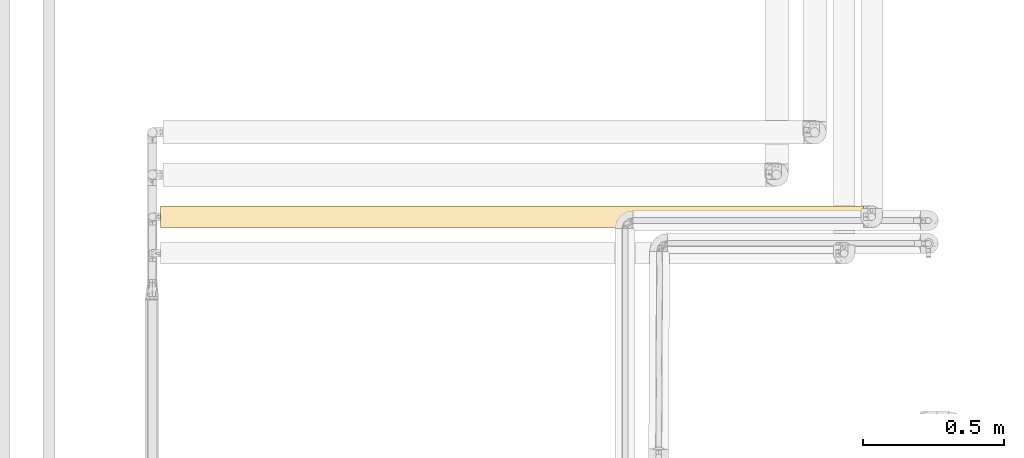
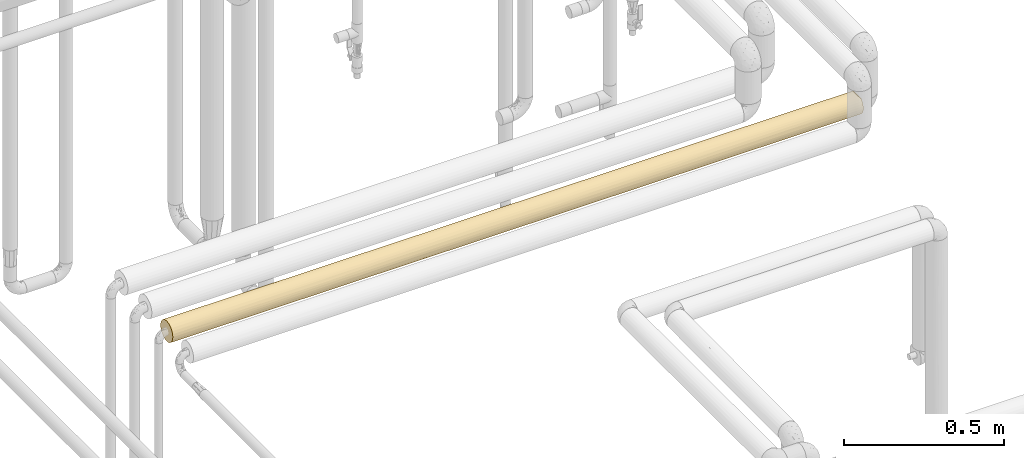
# One storey, part 31 of 827: 1 covering.
"""IFC2X3 building model written with IfcOpenShell, lengths in millimetres."""

from ifc_helpers import new_model, entity, si_unit, converted_unit, derived_unit, direction, frame, origin, place, context, subcontext, project, spatial, faceted_brep, element, save


model = new_model("IFC2X3")

# Units and contexts
model_context = context("Model", 3, precision=0.01, world=origin(), true_north=direction((6.12303176911189e-17, 1.0)))
body_context = subcontext(model_context, "Body", "Model", "MODEL_VIEW")
ifc_project = project(units=[si_unit("LENGTHUNIT", "METRE", prefix="MILLI"), si_unit("AREAUNIT", "SQUARE_METRE"), si_unit("VOLUMEUNIT", "CUBIC_METRE"), converted_unit("PLANEANGLEUNIT", "DEGREE", entity("IfcRatioMeasure", 0.0174532925199433), si_unit("PLANEANGLEUNIT", "RADIAN"), dimensions=[0, 0, 0, 0, 0, 0, 0]), si_unit("MASSUNIT", "GRAM", prefix="KILO"), derived_unit("MASSDENSITYUNIT", [(si_unit("MASSUNIT", "GRAM", prefix="KILO"), 1), (si_unit("LENGTHUNIT", "METRE"), -3)]), derived_unit("MOMENTOFINERTIAUNIT", [(si_unit("LENGTHUNIT", "METRE"), 4)]), si_unit("TIMEUNIT", "SECOND"), si_unit("FREQUENCYUNIT", "HERTZ"), si_unit("THERMODYNAMICTEMPERATUREUNIT", "DEGREE_CELSIUS"), derived_unit("THERMALTRANSMITTANCEUNIT", [(si_unit("MASSUNIT", "GRAM", prefix="KILO"), 1), (si_unit("THERMODYNAMICTEMPERATUREUNIT", "KELVIN"), -1), (si_unit("TIMEUNIT", "SECOND"), -3)]), derived_unit("VOLUMETRICFLOWRATEUNIT", [(si_unit("LENGTHUNIT", "METRE"), 3), (si_unit("TIMEUNIT", "SECOND"), -1)]), derived_unit("MASSFLOWRATEUNIT", [(si_unit("MASSUNIT", "GRAM", prefix="KILO"), 1), (si_unit("TIMEUNIT", "SECOND"), -1)]), derived_unit("ROTATIONALFREQUENCYUNIT", [(si_unit("TIMEUNIT", "SECOND"), -1)]), si_unit("ELECTRICCURRENTUNIT", "AMPERE"), si_unit("ELECTRICVOLTAGEUNIT", "VOLT"), si_unit("POWERUNIT", "WATT"), si_unit("FORCEUNIT", "NEWTON", prefix="KILO"), si_unit("ILLUMINANCEUNIT", "LUX"), si_unit("LUMINOUSFLUXUNIT", "LUMEN"), si_unit("LUMINOUSINTENSITYUNIT", "CANDELA"), derived_unit("USERDEFINED", [(si_unit("MASSUNIT", "GRAM", prefix="KILO"), -1), (si_unit("LENGTHUNIT", "METRE"), -2), (si_unit("TIMEUNIT", "SECOND"), 3), (si_unit("LUMINOUSFLUXUNIT", "LUMEN"), 1)]), derived_unit("LINEARVELOCITYUNIT", [(si_unit("LENGTHUNIT", "METRE"), 1), (si_unit("TIMEUNIT", "SECOND"), -1)]), si_unit("PRESSUREUNIT", "PASCAL"), derived_unit("USERDEFINED", [(si_unit("LENGTHUNIT", "METRE"), -2), (si_unit("MASSUNIT", "GRAM", prefix="KILO"), 1), (si_unit("TIMEUNIT", "SECOND"), -2)]), derived_unit("LINEARFORCEUNIT", [(si_unit("MASSUNIT", "GRAM", prefix="KILO"), 1), (si_unit("LENGTHUNIT", "METRE"), 1), (si_unit("TIMEUNIT", "SECOND"), -2), (si_unit("LENGTHUNIT", "METRE"), -1)]), derived_unit("PLANARFORCEUNIT", [(si_unit("MASSUNIT", "GRAM", prefix="KILO"), 1), (si_unit("LENGTHUNIT", "METRE"), 1), (si_unit("TIMEUNIT", "SECOND"), -2), (si_unit("LENGTHUNIT", "METRE"), -2)])], contexts=[model_context])

# Site, building, storey
site_placement = place(None, origin())
site = spatial("IfcSite", under=ifc_project, at=site_placement, CompositionType="ELEMENT")
building_placement = place(site_placement, origin())
building = spatial("IfcBuilding", under=site, at=building_placement, CompositionType="ELEMENT")
storey_placement = place(building_placement, frame((0.0, 0.0, 28200.0)))
storey = spatial("IfcBuildingStorey", under=building, at=storey_placement, Name="08", CompositionType="ELEMENT", Elevation=28200.0)

# Covering
covering_placement = place(storey_placement, frame((16157.15, 12910.0, 2360.0)))
element("IfcCovering", 1, at=covering_placement, inside=storey, Name=":ADSK_", ObjectType=":ADSK_", PredefinedType="INSULATION", context=body_context, shape_type="Brep", body=[
    faceted_brep([(0.0, 6.74, 20.8), (0.0, 2.9, 30.06), (0.0, 1.6, 40.0), (0.0, 2.9, 49.93), (0.0, 6.74, 59.2), (0.0, 12.84, 67.15), (0.0, 20.8, 73.25), (0.0, 30.06, 77.09), (0.0, 40.0, 78.4), (0.0, 49.93, 77.09), (0.0, 59.2, 73.25), (0.0, 67.15, 67.15), (0.0, 73.25, 59.2), (0.0, 77.09, 49.93), (0.0, 78.4, 40.0), (0.0, 77.09, 30.06), (0.0, 73.25, 20.8), (0.0, 67.15, 12.84), (0.0, 59.2, 6.74), (0.0, 49.93, 2.9), (0.0, 40.0, 1.6), (0.0, 30.06, 2.9), (0.0, 20.8, 6.74), (0.0, 12.84, 12.84), (2496.8, 2.9, 30.06), (2496.8, 6.74, 20.8), (2496.8, 12.84, 12.84), (2496.8, 20.8, 6.74), (2496.8, 30.06, 2.9), (2496.8, 40.0, 1.6), (2496.8, 49.93, 2.9), (2496.8, 59.2, 6.74), (2496.8, 67.15, 12.84), (2496.8, 73.25, 20.8), (2496.8, 77.09, 30.06), (2496.8, 78.4, 40.0), (2496.8, 77.51, 48.2), (2496.8, 74.9, 56.01), (2496.8, 70.68, 63.08), (2496.8, 65.05, 69.1), (2496.8, 14.94, 69.1), (2496.8, 9.31, 63.08), (2496.8, 5.09, 56.01), (2496.8, 2.48, 48.2), (2496.8, 1.6, 40.0), (2251.75, 54.69, 4.52), (2172.24, 47.28, 2.29), (1967.08, 54.69, 4.52), (484.12, 68.04, 13.77), (310.15, 63.37, 9.53), (256.55, 70.46, 16.62), (798.66, 58.01, 6.08), (670.09, 48.36, 2.52), (492.5, 54.69, 4.52), (2237.61, 70.46, 16.62), (299.64, 47.43, 2.32), (574.36, 40.0, 1.6), (432.75, 40.0, 1.6), (382.91, 40.0, 1.6), (216.37, 40.0, 1.6), (227.87, 77.81, 33.33), (216.37, 78.4, 40.0), (382.91, 78.4, 40.0), (224.95, 54.69, 4.52), (1935.15, 46.88, 2.22), (1610.34, 52.37, 3.65), (2280.43, 40.0, 1.6), (1732.82, 62.09, 8.59), (1633.27, 77.48, 31.66), (1875.15, 77.57, 32.07), (1739.69, 75.13, 24.5), (400.07, 75.47, 25.3), (173.81, 75.47, 25.3), (2172.53, 63.37, 9.53), (2172.24, 77.7, 32.71), (2064.05, 78.4, 40.0), (1122.32, 57.61, 5.88), (982.19, 47.77, 2.39), (2302.15, 76.1, 26.92), (2091.48, 75.47, 25.3), (1550.77, 70.19, 16.27), (1355.68, 67.75, 13.46), (1362.96, 72.58, 19.67), (516.07, 72.57, 19.66), (711.69, 70.46, 16.62), (2280.43, 78.4, 40.0), (1952.89, 62.68, 9.01), (1773.14, 70.46, 16.62), (1960.03, 72.71, 19.89), (2005.37, 68.23, 13.97), (1414.93, 40.0, 1.6), (1263.23, 49.56, 2.81), (690.15, 64.48, 10.42), (574.36, 77.71, 32.75), (574.37, 78.4, 40.0), (765.82, 78.4, 40.0), (665.91, 75.11, 24.46), (2113.89, 40.0, 1.6), (2064.05, 40.0, 1.6), (1847.68, 40.0, 1.6), (1730.98, 40.0, 1.6), (1631.31, 40.0, 1.6), (1198.56, 40.0, 1.6), (1389.6, 57.21, 5.67), (765.82, 40.0, 1.6), (971.75, 65.84, 11.59), (1306.75, 77.65, 32.47), (1456.77, 75.79, 26.08), (1034.63, 71.92, 18.66), (982.19, 76.15, 27.06), (1216.45, 75.35, 25.02), (786.81, 77.22, 30.56), (982.19, 78.4, 40.0), (1414.93, 78.4, 40.0), (1631.31, 78.4, 40.0), (1847.68, 78.4, 40.0), (649.12, 40.0, 1.6), (1081.86, 40.0, 1.6), (982.19, 40.0, 1.6), (865.49, 40.0, 1.6), (1198.56, 78.4, 40.0), (1514.61, 40.0, 1.6), (1298.24, 40.0, 1.6), (2237.61, 16.62, 9.53), (2172.53, 9.53, 16.62), (937.47, 3.8, 27.17), (907.59, 7.19, 20.04), (1124.83, 5.72, 22.69), (2251.75, 4.52, 25.3), (1802.5, 27.74, 3.6), (1996.55, 32.65, 2.3), (2096.73, 25.3, 4.52), (2252.24, 32.58, 2.32), (2320.77, 25.5, 4.44), (864.09, 27.72, 3.61), (832.03, 17.37, 8.97), (529.72, 25.3, 4.52), (2280.43, 1.6, 40.0), (324.27, 16.62, 9.53), (259.19, 9.53, 16.62), (400.07, 4.52, 25.3), (492.94, 2.31, 32.64), (239.86, 2.28, 32.79), (245.05, 25.3, 4.52), (561.65, 33.12, 2.22), (1632.71, 3.61, 27.72), (1664.77, 8.97, 17.37), (1967.08, 4.52, 25.3), (665.96, 3.83, 27.08), (2172.24, 2.29, 32.71), (1065.96, 10.54, 15.36), (711.69, 9.53, 16.62), (1512.55, 24.82, 4.72), (1565.64, 18.15, 8.41), (324.56, 32.71, 2.29), (1935.15, 2.22, 33.12), (178.26, 4.36, 25.7), (1785.11, 16.62, 9.53), (1971.22, 19.82, 7.32), (567.65, 17.88, 8.6), (485.44, 11.8, 13.93), (525.58, 7.32, 19.82), (1929.15, 8.6, 17.88), (2011.36, 13.93, 11.8), (1147.5, 31.05, 2.65), (1395.32, 14.11, 11.63), (1354.91, 6.42, 21.36), (1349.3, 2.65, 31.05), (1141.89, 21.36, 6.42), (1611.19, 31.2, 2.62), (1041.42, 15.85, 10.13), (1139.03, 3.03, 29.61), (982.19, 1.6, 40.0), (1395.0, 32.08, 2.42), (2064.05, 1.6, 40.0), (1847.68, 1.6, 40.0), (1631.31, 1.6, 40.0), (1414.93, 1.6, 40.0), (1198.56, 1.6, 40.0), (765.82, 1.6, 40.0), (574.36, 1.6, 40.0), (382.91, 1.6, 40.0), (216.37, 1.6, 40.0), (2211.16, 3.58, 52.17), (2279.74, 7.01, 59.66), (2013.22, 7.01, 59.66), (670.09, 2.52, 48.36), (492.5, 4.52, 54.69), (299.64, 2.32, 47.43), (2489.9, 26.63, 76.0), (2488.1, 33.21, 77.79), (2162.94, 31.75, 77.5), (1683.4, 24.01, 74.91), (1892.34, 22.88, 74.37), (1810.33, 29.53, 76.94), (2113.4, 23.31, 74.58), (2156.13, 17.21, 70.91), (2492.83, 20.48, 73.07), (2211.15, 11.96, 66.24), (1263.24, 2.81, 49.56), (1122.75, 5.88, 57.62), (982.19, 2.39, 47.77), (224.95, 4.52, 54.69), (1303.64, 11.34, 65.56), (971.98, 11.61, 65.85), (2271.13, 40.0, 78.4), (2054.75, 40.0, 78.4), (310.15, 9.53, 63.37), (378.26, 40.0, 78.4), (226.91, 33.29, 77.81), (452.74, 32.61, 77.68), (399.8, 25.3, 75.47), (520.84, 19.69, 72.59), (744.18, 27.18, 76.19), (173.66, 25.3, 75.47), (1503.27, 20.57, 73.12), (1500.16, 30.18, 77.12), (798.85, 6.09, 58.01), (1781.21, 17.22, 70.91), (1799.05, 10.38, 64.44), (1985.92, 13.92, 68.19), (256.55, 16.62, 70.46), (1881.58, 2.85, 49.74), (711.08, 16.62, 70.46), (992.17, 19.52, 72.48), (1788.09, 5.9, 57.67), (1564.96, 7.13, 59.85), (1584.37, 3.04, 50.42), (2487.5, 40.0, 78.4), (1838.38, 40.0, 78.4), (1622.01, 40.0, 78.4), (996.15, 27.38, 76.26), (689.87, 10.42, 64.48), (483.81, 13.77, 68.04), (1557.38, 13.35, 67.65), (1355.48, 5.37, 56.6), (1228.38, 17.39, 71.04), (1235.65, 24.84, 75.28), (1405.64, 40.0, 78.4), (1175.42, 32.13, 77.58), (756.52, 40.0, 78.4), (1189.26, 40.0, 78.4), (972.89, 40.0, 78.4), (2211.15, 68.03, 66.24), (2279.74, 72.98, 59.66), (2211.16, 76.41, 52.17), (2149.49, 62.82, 70.87), (2489.9, 53.36, 76.0), (2492.83, 59.51, 73.07), (2113.4, 56.68, 74.58), (1507.33, 59.16, 73.27), (1228.38, 62.6, 71.04), (1235.65, 55.15, 75.28), (1513.82, 49.52, 77.19), (1810.33, 50.46, 76.94), (2162.94, 48.24, 77.5), (982.19, 77.6, 47.77), (1263.24, 77.18, 49.56), (224.95, 75.47, 54.69), (226.91, 46.7, 77.81), (2013.22, 72.98, 59.66), (483.81, 66.22, 68.04), (310.15, 70.46, 63.37), (256.55, 63.37, 70.46), (1792.27, 69.69, 64.34), (1788.01, 74.17, 57.5), (1564.96, 72.86, 59.85), (1881.58, 77.14, 49.74), (492.5, 75.47, 54.69), (670.09, 77.47, 48.36), (299.64, 77.67, 47.43), (744.18, 52.81, 76.19), (996.15, 52.61, 76.26), (992.17, 60.48, 72.48), (173.66, 54.69, 75.47), (1982.73, 66.24, 68.03), (2488.1, 46.78, 77.79), (798.85, 73.9, 58.01), (399.8, 54.69, 75.47), (711.08, 63.37, 70.46), (971.98, 68.39, 65.85), (1122.75, 74.11, 57.62), (1892.34, 57.11, 74.37), (1553.43, 66.43, 67.84), (1303.64, 68.65, 65.56), (1175.42, 47.86, 77.58), (689.87, 69.58, 64.48), (1584.37, 76.95, 50.42), (452.74, 47.38, 77.68), (520.84, 60.3, 72.59), (1355.48, 74.62, 56.6), (1781.21, 62.77, 70.91)], [[[0, 1, 2, 3, 4, 5, 6, 7, 8, 9, 10, 11, 12, 13, 14, 15, 16, 17, 18, 19, 20, 21, 22, 23]], [[24, 25, 26, 27, 28, 29, 30, 31, 32, 33, 34, 35, 36, 37, 38, 39, 40, 41, 42, 43, 44]], [[45, 46, 47]], [[48, 49, 50]], [[31, 30, 45]], [[51, 52, 53]], [[49, 17, 50]], [[33, 32, 54]], [[55, 56, 57, 58, 59]], [[60, 14, 61, 62]], [[18, 63, 19]], [[47, 64, 65]], [[30, 29, 66]], [[19, 59, 20]], [[65, 67, 47]], [[68, 69, 70]], [[71, 72, 60]], [[63, 49, 53]], [[73, 45, 47]], [[53, 52, 55]], [[15, 72, 16]], [[74, 69, 75]], [[51, 76, 77]], [[74, 78, 79]], [[80, 81, 82]], [[49, 18, 17]], [[54, 32, 73]], [[31, 45, 73]], [[34, 78, 74]], [[31, 73, 32]], [[48, 83, 84]], [[69, 79, 70]], [[34, 74, 85]], [[86, 67, 87]], [[47, 46, 64]], [[88, 54, 89]], [[81, 80, 67]], [[65, 90, 91]], [[17, 16, 50]], [[53, 49, 92]], [[89, 54, 73]], [[93, 62, 94, 95]], [[78, 54, 79]], [[72, 50, 16]], [[71, 96, 83]], [[66, 46, 30]], [[49, 63, 18]], [[55, 19, 63]], [[46, 66, 97, 98]], [[46, 98, 64]], [[30, 46, 45]], [[64, 98, 99, 100, 101]], [[65, 64, 101]], [[102, 77, 91]], [[67, 65, 103]], [[65, 91, 103]], [[77, 104, 52]], [[87, 89, 86]], [[51, 105, 76]], [[106, 68, 107]], [[108, 109, 110]], [[71, 93, 96]], [[111, 95, 112]], [[68, 113, 114, 115]], [[109, 106, 110]], [[56, 55, 52]], [[19, 55, 59]], [[53, 55, 63]], [[52, 104, 116, 56]], [[77, 102, 117, 118, 119, 104]], [[92, 49, 48]], [[51, 92, 105]], [[51, 77, 52]], [[91, 77, 76]], [[84, 96, 108]], [[81, 76, 105]], [[103, 91, 76]], [[84, 83, 96]], [[76, 81, 103]], [[67, 103, 81]], [[96, 111, 109]], [[60, 93, 71]], [[111, 96, 93]], [[108, 96, 109]], [[85, 74, 75]], [[85, 35, 34]], [[69, 74, 79]], [[88, 70, 79]], [[68, 115, 69]], [[34, 33, 78]], [[54, 78, 33]], [[83, 50, 71]], [[92, 48, 84]], [[105, 92, 84]], [[53, 92, 51]], [[89, 73, 86]], [[88, 89, 87]], [[73, 47, 86]], [[47, 67, 86]], [[88, 87, 70]], [[54, 88, 79]], [[70, 87, 80]], [[70, 107, 68]], [[113, 68, 106]], [[113, 106, 112, 120]], [[110, 106, 107]], [[111, 112, 109]], [[107, 82, 110]], [[108, 81, 105]], [[108, 110, 82]], [[84, 108, 105]], [[107, 70, 80]], [[108, 82, 81]], [[80, 82, 107]], [[67, 80, 87]], [[93, 95, 111]], [[106, 109, 112]], [[65, 101, 121, 90]], [[91, 90, 122, 102]], [[50, 83, 48]], [[60, 72, 15]], [[50, 72, 71]], [[14, 60, 15]], [[60, 62, 93]], [[115, 75, 69]], [[123, 26, 124]], [[125, 126, 127]], [[25, 124, 26]], [[128, 25, 24]], [[26, 123, 27]], [[129, 130, 131]], [[132, 133, 131]], [[134, 135, 136]], [[24, 44, 137]], [[23, 138, 139]], [[21, 20, 59]], [[140, 141, 142]], [[21, 143, 22]], [[144, 134, 136]], [[145, 146, 147]], [[148, 141, 140]], [[128, 149, 147]], [[150, 126, 151]], [[152, 129, 153]], [[143, 154, 136]], [[0, 23, 139]], [[22, 143, 138]], [[25, 128, 124]], [[22, 138, 23]], [[155, 145, 147]], [[142, 156, 140]], [[157, 129, 158]], [[131, 130, 132]], [[138, 159, 160]], [[136, 154, 144]], [[161, 139, 160]], [[124, 162, 163]], [[147, 149, 155]], [[158, 123, 163]], [[164, 119, 118, 117, 102, 122]], [[150, 165, 166]], [[145, 167, 166]], [[150, 151, 135]], [[160, 139, 138]], [[1, 142, 2]], [[28, 132, 29]], [[156, 139, 140]], [[163, 123, 124]], [[133, 123, 131]], [[59, 154, 21]], [[138, 143, 136]], [[137, 149, 24]], [[124, 128, 147]], [[154, 59, 58, 57]], [[154, 57, 144]], [[21, 154, 143]], [[144, 57, 56, 116, 104, 119]], [[134, 168, 135]], [[144, 119, 134]], [[129, 152, 169]], [[134, 164, 168]], [[165, 150, 170]], [[160, 159, 151]], [[168, 170, 135]], [[171, 127, 166]], [[140, 161, 148]], [[148, 161, 151]], [[171, 172, 125]], [[152, 165, 168]], [[165, 153, 146]], [[168, 164, 173]], [[158, 129, 131]], [[149, 137, 174]], [[149, 174, 155]], [[24, 149, 128]], [[155, 174, 175, 176]], [[145, 166, 146]], [[155, 176, 145]], [[167, 176, 177, 178]], [[165, 146, 166]], [[163, 162, 157]], [[176, 167, 145]], [[173, 164, 122]], [[171, 178, 172]], [[127, 171, 125]], [[138, 136, 159]], [[161, 160, 151]], [[136, 135, 159]], [[151, 159, 135]], [[151, 126, 148]], [[139, 161, 140]], [[141, 179, 180, 181]], [[179, 141, 148]], [[142, 141, 181]], [[142, 181, 182, 2]], [[142, 1, 156]], [[1, 0, 156]], [[139, 156, 0]], [[124, 147, 162]], [[158, 163, 157]], [[147, 146, 162]], [[157, 162, 146]], [[157, 153, 129]], [[123, 158, 131]], [[169, 152, 173]], [[130, 100, 99, 98, 97]], [[169, 121, 101, 100]], [[168, 173, 152]], [[173, 122, 90, 121]], [[121, 169, 173]], [[100, 129, 169]], [[100, 130, 129]], [[132, 130, 97]], [[132, 97, 66, 29]], [[132, 28, 133]], [[28, 27, 133]], [[123, 133, 27]], [[165, 170, 168]], [[150, 135, 170]], [[127, 150, 166]], [[148, 126, 125]], [[150, 127, 126]], [[171, 166, 167]], [[167, 178, 171]], [[172, 179, 125]], [[146, 153, 157]], [[165, 152, 153]], [[119, 164, 134]], [[179, 148, 125]], [[183, 184, 185]], [[186, 187, 188]], [[184, 42, 41]], [[189, 190, 191]], [[192, 193, 194]], [[195, 196, 197]], [[198, 184, 41]], [[199, 200, 201]], [[183, 137, 43]], [[3, 2, 182]], [[202, 188, 187]], [[200, 203, 204]], [[191, 205, 206]], [[4, 207, 5]], [[189, 195, 197]], [[40, 198, 41]], [[208, 209, 210]], [[211, 212, 213]], [[6, 214, 7]], [[215, 192, 216]], [[186, 217, 187]], [[4, 3, 202]], [[218, 219, 220]], [[5, 221, 6]], [[207, 221, 5]], [[191, 194, 195]], [[183, 222, 174]], [[205, 191, 190]], [[42, 183, 43]], [[4, 202, 207]], [[213, 223, 224]], [[7, 214, 209]], [[196, 40, 197]], [[193, 220, 196]], [[222, 183, 185]], [[43, 137, 44]], [[201, 179, 172, 178]], [[225, 226, 227]], [[190, 228, 205]], [[194, 206, 229, 230]], [[191, 195, 189]], [[216, 194, 230]], [[193, 195, 194]], [[213, 224, 231]], [[232, 204, 223]], [[187, 217, 232]], [[181, 180, 188, 182]], [[212, 221, 233]], [[185, 219, 225]], [[222, 176, 175, 174]], [[218, 234, 219]], [[218, 193, 192]], [[233, 221, 207]], [[7, 209, 8]], [[174, 137, 183]], [[214, 221, 211]], [[182, 188, 3]], [[207, 202, 187]], [[186, 180, 179]], [[3, 188, 202]], [[180, 186, 188]], [[179, 201, 186]], [[186, 201, 217]], [[204, 217, 200]], [[222, 225, 227]], [[232, 223, 233]], [[199, 201, 178]], [[217, 201, 200]], [[200, 235, 203]], [[224, 223, 204]], [[215, 234, 218]], [[224, 236, 237]], [[177, 176, 227]], [[235, 200, 199]], [[236, 204, 203]], [[224, 237, 231]], [[216, 238, 239]], [[210, 240, 208]], [[238, 241, 242, 239]], [[199, 178, 177]], [[216, 237, 215]], [[236, 215, 237]], [[215, 236, 234]], [[203, 226, 234]], [[226, 225, 219]], [[226, 219, 234]], [[220, 185, 198]], [[185, 220, 219]], [[196, 220, 198]], [[196, 198, 40]], [[193, 196, 195]], [[207, 187, 232]], [[212, 233, 223]], [[232, 233, 207]], [[204, 232, 217]], [[213, 212, 223]], [[221, 212, 211]], [[204, 236, 224]], [[222, 185, 225]], [[237, 239, 231]], [[242, 231, 239]], [[216, 239, 237]], [[240, 213, 242]], [[213, 231, 242]], [[226, 235, 227]], [[236, 203, 234]], [[199, 177, 227]], [[203, 235, 226]], [[199, 227, 235]], [[216, 230, 238]], [[185, 184, 198]], [[42, 184, 183]], [[221, 214, 6]], [[211, 210, 209]], [[211, 209, 214]], [[8, 209, 208]], [[211, 213, 210]], [[240, 210, 213]], [[206, 194, 191]], [[220, 193, 218]], [[216, 192, 194]], [[218, 192, 215]], [[176, 222, 227]], [[243, 38, 244]], [[245, 244, 37]], [[39, 243, 246]], [[247, 248, 249]], [[250, 251, 252]], [[250, 253, 254]], [[255, 254, 206]], [[120, 256, 257]], [[243, 39, 38]], [[12, 258, 13]], [[8, 208, 259]], [[243, 244, 260]], [[261, 262, 263]], [[262, 12, 11]], [[264, 265, 266]], [[229, 206, 254, 230]], [[11, 263, 262]], [[245, 37, 36]], [[260, 245, 267]], [[268, 269, 270]], [[271, 272, 273]], [[9, 274, 10]], [[260, 264, 275]], [[246, 243, 275]], [[262, 268, 258]], [[270, 94, 62, 61]], [[75, 245, 85]], [[276, 247, 255]], [[205, 228, 276]], [[277, 269, 268]], [[278, 274, 259]], [[279, 271, 273]], [[255, 247, 249]], [[206, 205, 255]], [[246, 248, 39]], [[245, 36, 85]], [[267, 245, 75]], [[277, 280, 281]], [[256, 120, 112, 95]], [[276, 255, 205]], [[255, 249, 254]], [[249, 282, 254]], [[283, 284, 251]], [[254, 282, 250]], [[285, 242, 241, 238]], [[11, 10, 263]], [[13, 61, 14]], [[268, 262, 286]], [[114, 267, 75, 115]], [[287, 113, 257]], [[281, 280, 284]], [[266, 283, 264]], [[36, 35, 85]], [[288, 240, 271]], [[274, 263, 10]], [[261, 289, 279]], [[262, 258, 12]], [[270, 13, 258]], [[94, 270, 269]], [[13, 270, 61]], [[268, 270, 258]], [[94, 269, 95]], [[281, 256, 277]], [[286, 262, 261]], [[277, 286, 280]], [[277, 256, 269]], [[269, 256, 95]], [[257, 256, 281]], [[279, 273, 280]], [[284, 266, 290]], [[251, 280, 273]], [[250, 252, 253]], [[281, 290, 257]], [[287, 265, 267]], [[289, 271, 279]], [[251, 273, 252]], [[288, 278, 259]], [[272, 252, 273]], [[230, 253, 238]], [[238, 253, 285]], [[230, 254, 253]], [[253, 252, 285]], [[283, 250, 291]], [[250, 283, 251]], [[264, 283, 291]], [[266, 284, 283]], [[275, 264, 291]], [[264, 260, 265]], [[282, 246, 275]], [[260, 275, 243]], [[282, 275, 291]], [[248, 246, 249]], [[289, 263, 278]], [[286, 261, 279]], [[280, 286, 279]], [[268, 286, 277]], [[263, 289, 261]], [[271, 289, 278]], [[260, 267, 265]], [[290, 266, 287]], [[272, 242, 285]], [[285, 252, 272]], [[271, 242, 272]], [[242, 271, 240]], [[290, 287, 257]], [[113, 120, 257]], [[280, 251, 284]], [[284, 290, 281]], [[265, 287, 266]], [[114, 287, 267]], [[287, 114, 113]], [[37, 244, 38]], [[260, 244, 245]], [[259, 274, 9]], [[263, 274, 278]], [[8, 259, 9]], [[259, 208, 288]], [[240, 288, 208]], [[271, 278, 288]], [[246, 282, 249]], [[250, 282, 291]], [[228, 190, 189, 197, 40, 39, 248, 247, 276]]]),
])

save(model, "model.ifc")
